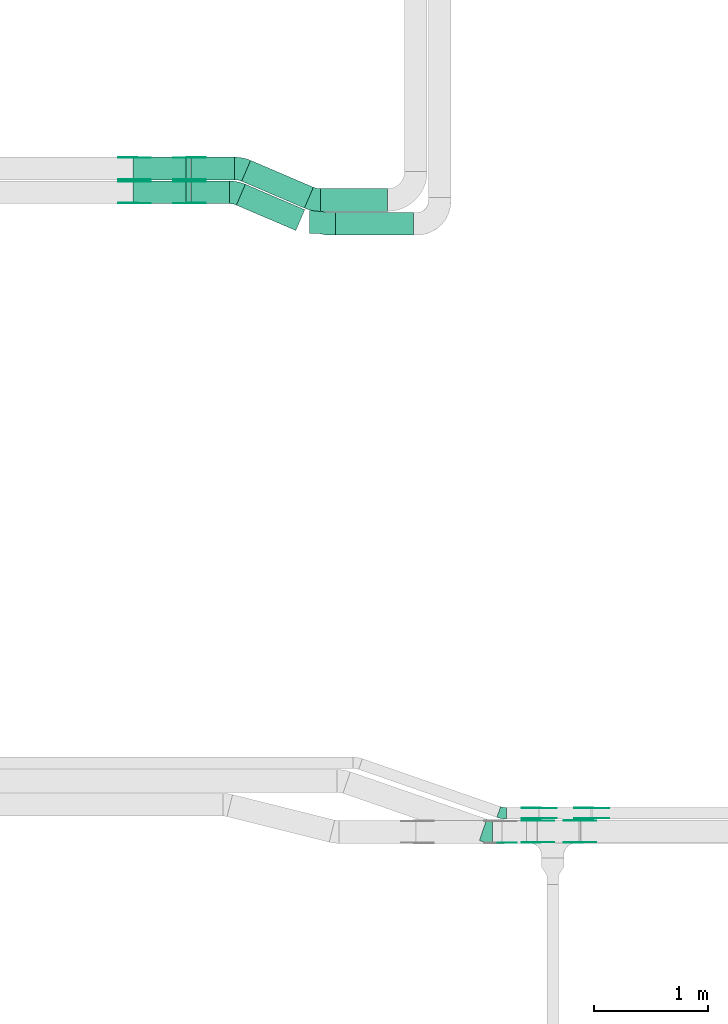
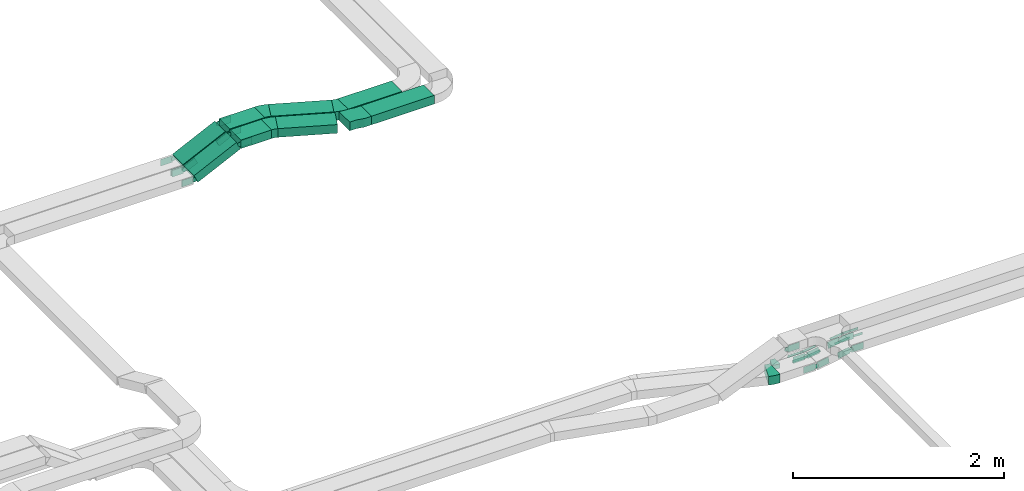
# One storey, part 14 of 23: 39 flow fittings, 8 flow segments.
"""IFC2X3 building model written with IfcOpenShell, lengths in millimetres."""

from ifc_helpers import new_model, entity, si_unit, converted_unit, derived_unit, direction, frame, frame_2d, origin, origin_2d_with_axis, place, context, subcontext, project, spatial, polyline, circle_curve, parameter, trimmed, segment, composite_curve, rectangle, outline, extrude, source, transform, mapped, material, type_object, type_shapes, element, save


model = new_model("IFC2X3")

# Units and contexts
model_context = context("Model", 3, precision=0.01, world=origin(), true_north=direction((6.12303176911189e-17, 1.0)))
body_context = subcontext(model_context, "Body", "Model", "MODEL_VIEW")
ifc_project = project(units=[si_unit("LENGTHUNIT", "METRE", prefix="MILLI"), si_unit("AREAUNIT", "SQUARE_METRE"), si_unit("VOLUMEUNIT", "CUBIC_METRE"), converted_unit("PLANEANGLEUNIT", "DEGREE", entity("IfcRatioMeasure", 0.0174532925199433), si_unit("PLANEANGLEUNIT", "RADIAN"), dimensions=[0, 0, 0, 0, 0, 0, 0]), si_unit("MASSUNIT", "GRAM", prefix="KILO"), derived_unit("MASSDENSITYUNIT", [(si_unit("MASSUNIT", "GRAM", prefix="KILO"), 1), (si_unit("LENGTHUNIT", "METRE"), -3)]), derived_unit("MOMENTOFINERTIAUNIT", [(si_unit("LENGTHUNIT", "METRE"), 4)]), si_unit("TIMEUNIT", "SECOND"), si_unit("FREQUENCYUNIT", "HERTZ"), si_unit("THERMODYNAMICTEMPERATUREUNIT", "DEGREE_CELSIUS"), derived_unit("THERMALTRANSMITTANCEUNIT", [(si_unit("MASSUNIT", "GRAM", prefix="KILO"), 1), (si_unit("THERMODYNAMICTEMPERATUREUNIT", "KELVIN"), -1), (si_unit("TIMEUNIT", "SECOND"), -3)]), derived_unit("VOLUMETRICFLOWRATEUNIT", [(si_unit("LENGTHUNIT", "METRE"), 3), (si_unit("TIMEUNIT", "SECOND"), -1)]), derived_unit("MASSFLOWRATEUNIT", [(si_unit("MASSUNIT", "GRAM", prefix="KILO"), 1), (si_unit("TIMEUNIT", "SECOND"), -1)]), derived_unit("ROTATIONALFREQUENCYUNIT", [(si_unit("TIMEUNIT", "SECOND"), -1)]), si_unit("ELECTRICCURRENTUNIT", "AMPERE"), si_unit("ELECTRICVOLTAGEUNIT", "VOLT"), si_unit("POWERUNIT", "WATT"), si_unit("FORCEUNIT", "NEWTON", prefix="KILO"), si_unit("ILLUMINANCEUNIT", "LUX"), si_unit("LUMINOUSFLUXUNIT", "LUMEN"), si_unit("LUMINOUSINTENSITYUNIT", "CANDELA"), derived_unit("USERDEFINED", [(si_unit("MASSUNIT", "GRAM", prefix="KILO"), -1), (si_unit("LENGTHUNIT", "METRE"), -2), (si_unit("TIMEUNIT", "SECOND"), 3), (si_unit("LUMINOUSFLUXUNIT", "LUMEN"), 1)]), derived_unit("LINEARVELOCITYUNIT", [(si_unit("LENGTHUNIT", "METRE"), 1), (si_unit("TIMEUNIT", "SECOND"), -1)]), si_unit("PRESSUREUNIT", "PASCAL"), derived_unit("USERDEFINED", [(si_unit("LENGTHUNIT", "METRE"), -2), (si_unit("MASSUNIT", "GRAM", prefix="KILO"), 1), (si_unit("TIMEUNIT", "SECOND"), -2)]), derived_unit("LINEARFORCEUNIT", [(si_unit("MASSUNIT", "GRAM", prefix="KILO"), 1), (si_unit("LENGTHUNIT", "METRE"), 1), (si_unit("TIMEUNIT", "SECOND"), -2), (si_unit("LENGTHUNIT", "METRE"), -1)]), derived_unit("PLANARFORCEUNIT", [(si_unit("MASSUNIT", "GRAM", prefix="KILO"), 1), (si_unit("LENGTHUNIT", "METRE"), 1), (si_unit("TIMEUNIT", "SECOND"), -2), (si_unit("LENGTHUNIT", "METRE"), -2)])], contexts=[model_context])

# Site, building, storey
site_placement = place(None, origin())
site = spatial("IfcSite", under=ifc_project, at=site_placement, CompositionType="ELEMENT")
building_placement = place(site_placement, origin())
building = spatial("IfcBuilding", under=site, at=building_placement, CompositionType="ELEMENT")
storey_placement = place(building_placement, frame((0.0, 0.0, 24000.0)))
storey = spatial("IfcBuildingStorey", under=building, at=storey_placement, CompositionType="ELEMENT", Elevation=24000.0)

# Flow segments
cable_carrier_segment_type = type_object("IfcCableCarrierSegmentType", PredefinedType="CABLETRAYSEGMENT")
flow_segment_1_placement = place(storey_placement, frame((39514.1, 14090.31, 2883.62)))
element("IfcFlowSegment", 1, at=flow_segment_1_placement, inside=storey, type_object=cable_carrier_segment_type, context=body_context, shape_type="SweptSolid", body=[
    extrude(rectangle(XDim=686.50102542503, YDim=199.999999999998, at=origin_2d_with_axis()), frame((343.25, 100.0, 0.0), z_axis=(0.0, 0.0, 1.0), x_axis=(-1.0, 0.0, 0.0)), (0.0, 0.0, 1.0), 100.000000000003),
])
flow_segment_2_placement = place(storey_placement, frame((39379.23, 14300.31, 2883.62)))
element("IfcFlowSegment", 2, at=flow_segment_2_placement, inside=storey, type_object=cable_carrier_segment_type, context=body_context, shape_type="SweptSolid", body=[
    extrude(rectangle(XDim=590.372485318248, YDim=199.999999999998, at=origin_2d_with_axis()), frame((295.19, 100.0, 0.0), z_axis=(0.0, 0.0, 1.0), x_axis=(-1.0, 0.0, 0.0)), (0.0, 0.0, 1.0), 100.000000000003),
])
flow_segment_3_placement = place(storey_placement, frame((38242.05, 14367.82, 2883.62)))
element("IfcFlowSegment", 3, at=flow_segment_3_placement, inside=storey, type_object=cable_carrier_segment_type, context=body_context, shape_type="SweptSolid", body=[
    extrude(rectangle(XDim=337.638555069506, YDim=199.999999999998, at=origin_2d_with_axis()), frame((168.82, 100.0, 0.0), z_axis=(0.0, 0.0, 1.0), x_axis=(-1.0, 0.0, 0.0)), (0.0, 0.0, 1.0), 100.000000000003),
])
flow_segment_4_placement = place(storey_placement, frame((38242.05, 14577.82, 2883.62)))
element("IfcFlowSegment", 4, at=flow_segment_4_placement, inside=storey, type_object=cable_carrier_segment_type, context=body_context, shape_type="SweptSolid", body=[
    extrude(rectangle(XDim=384.036141225792, YDim=199.999999999998, at=origin_2d_with_axis()), frame((192.02, 100.0, 0.0)), (0.0, 0.0, 1.0), 100.000000000003),
])
flow_segment_5_placement = place(storey_placement, frame((37730.99, 14367.82, 2660.62)))
element("IfcFlowSegment", 5, at=flow_segment_5_placement, inside=storey, type_object=cable_carrier_segment_type, context=body_context, shape_type="SweptSolid", body=[
    extrude(rectangle(XDim=99.9999999999961, YDim=200.000000000002, at=origin_2d_with_axis()), frame((21.58, 100.0, 45.1), z_axis=(0.90203010106071, 0.0, 0.431673136505395), x_axis=(-0.431673136505395, 0.0, 0.90203010106071)), (0.0, 0.0, 1.0), 514.687950468755),
])
flow_segment_6_placement = place(storey_placement, frame((37730.99, 14577.82, 2660.62)))
element("IfcFlowSegment", 6, at=flow_segment_6_placement, inside=storey, type_object=cable_carrier_segment_type, context=body_context, shape_type="SweptSolid", body=[
    extrude(rectangle(XDim=99.9999999999967, YDim=199.999999999998, at=origin_2d_with_axis()), frame((21.58, 100.0, 45.1), z_axis=(0.902030101062784, 0.0, 0.431673136501061), x_axis=(-0.431673136501061, 0.0, 0.902030101062784)), (0.0, 0.0, 1.0), 514.68795046868),
])
flow_segment_7_placement = place(storey_placement, frame((38640.61, 14131.35, 2883.62)))
element("IfcFlowSegment", 7, at=flow_segment_7_placement, inside=storey, type_object=cable_carrier_segment_type, context=body_context, shape_type="SweptSolid", body=[
    extrude(rectangle(XDim=569.477519390941, YDim=199.999999999997, at=origin_2d_with_axis()), frame((301.12, 203.93, 0.0), z_axis=(0.0, 0.0, 1.0), x_axis=(-0.919400368467263, 0.393322974745006, 0.0)), (0.0, 0.0, 1.0), 99.9999999999989),
])
flow_segment_8_placement = place(storey_placement, frame((38687.0, 14328.92, 2883.62)))
element("IfcFlowSegment", 8, at=flow_segment_8_placement, inside=storey, type_object=cable_carrier_segment_type, context=body_context, shape_type="SweptSolid", body=[
    extrude(rectangle(XDim=601.090303341187, YDim=199.999999999999, at=origin_2d_with_axis()), frame((315.65, 210.15, 0.0), z_axis=(0.0, 0.0, 1.0), x_axis=(-0.919400368467261, 0.393322974745012, 0.0)), (0.0, 0.0, 1.0), 100.000000000003),
])

# Flow fittings
ifc_material_1 = material()
cable_carrier_fitting_type_1 = type_object("IfcCableCarrierFittingType", PredefinedType="NOTDEFINED", material=ifc_material_1)
shared_shape_1 = source(origin(), body_context, "Body", "SweptSolid", [
    extrude(outline(polyline([(-115.0, 91.77), (-115.0, -108.23), (-38.33, -108.23), (38.33, -91.77), (115.0, -91.77), (115.0, 108.23), (38.33, 108.23), (-38.33, 91.77), (-115.0, 91.77)])), frame((115.0, -8.23, -50.0), z_axis=(0.0, 0.0, -1.0), x_axis=(1.0, 0.0, 0.0)), (0.0, 0.0, -1.0), 100.0),
])
type_shapes(cable_carrier_fitting_type_1, [shared_shape_1])
flow_fitting_1_placement = place(storey_placement, frame((39514.1, 14190.31, 2933.62), z_axis=(0.0, 0.0, 1.0), x_axis=(-1.0, 0.0, 0.0)))
element("IfcFlowFitting", 9, at=flow_fitting_1_placement, inside=storey, type_object=cable_carrier_fitting_type_1, material=ifc_material_1, Name="470_DKC_S5_adapter", context=body_context, shape_type="MappedRepresentation", body=[
    mapped(shared_shape_1, transform((0.0, 0.0, 0.0), scale=1.0)),
])
ifc_material_2 = material(Name="G")
cable_carrier_fitting_type_2 = type_object("IfcCableCarrierFittingType", PredefinedType="NOTDEFINED", material=ifc_material_2)
shared_shape_2 = source(origin(), body_context, "Body", "SweptSolid", [
    extrude(outline(composite_curve([segment(trimmed(circle_curve(frame_2d((-44.59, 0.0), x_axis=(1.0, 0.0)), 12.5), [parameter(90.0000000000007)], [parameter(270.0)], True, "PARAMETER"), True, "CONTINUOUS"), segment(polyline([(-44.59, -12.5), (-33.09, -12.5)]), True, "CONTINUOUS"), segment(polyline([(-33.09, -12.5), (-31.23, -14.5)]), True, "CONTINUOUS"), segment(polyline([(-31.23, -14.5), (108.91, -14.5)]), True, "CONTINUOUS"), segment(polyline([(108.91, -14.5), (108.91, 14.5)]), True, "CONTINUOUS"), segment(polyline([(108.91, 14.5), (-31.23, 14.5)]), True, "CONTINUOUS"), segment(polyline([(-31.23, 14.5), (-33.09, 12.5)]), True, "CONTINUOUS"), segment(polyline([(-33.09, 12.5), (-44.59, 12.5)]), True, "CONTINUOUS")], self_intersect=False)), frame((44.59, 0.0, 0.0), z_axis=(0.0, 0.0, -1.0), x_axis=(1.0, 0.0, 0.0)), (0.0, 0.0, -1.0), 2.0),
])
type_shapes(cable_carrier_fitting_type_2, [shared_shape_2])
flow_fitting_2_placement = place(storey_placement, frame((41768.97, 8954.53, 2745.0), z_axis=(0.0, -1.0, 0.0), x_axis=(-0.991697353687333, 0.0, -0.128593773914372)))
element("IfcFlowFitting", 10, at=flow_fitting_2_placement, inside=storey, type_object=cable_carrier_fitting_type_2, material=ifc_material_2, context=body_context, shape_type="MappedRepresentation", body=[
    mapped(shared_shape_2, transform((0.0, 0.0, 0.0), scale=1.0)),
])
cable_carrier_fitting_type_3 = type_object("IfcCableCarrierFittingType", PredefinedType="NOTDEFINED", material=ifc_material_2)
type_shapes(cable_carrier_fitting_type_3, [shared_shape_2])
flow_fitting_3_placement = place(storey_placement, frame((41768.97, 9043.45, 2745.0), z_axis=(0.0, 1.0, 0.0), x_axis=(1.0, 0.0, 0.0)))
element("IfcFlowFitting", 11, at=flow_fitting_3_placement, inside=storey, type_object=cable_carrier_fitting_type_3, material=ifc_material_2, context=body_context, shape_type="MappedRepresentation", body=[
    mapped(shared_shape_2, transform((0.0, 0.0, 0.0), scale=1.0)),
])
flow_fitting_4_placement = place(storey_placement, frame((41306.26, 9045.45, 2685.0), z_axis=(0.0, 1.0, 0.0), x_axis=(-1.0, 0.0, 0.0)))
element("IfcFlowFitting", 12, at=flow_fitting_4_placement, inside=storey, type_object=cable_carrier_fitting_type_2, material=ifc_material_2, context=body_context, shape_type="MappedRepresentation", body=[
    mapped(shared_shape_2, transform((0.0, 0.0, 0.0), scale=1.0)),
])
flow_fitting_5_placement = place(storey_placement, frame((41306.26, 8956.53, 2685.0), z_axis=(0.0, -1.0, 0.0), x_axis=(0.991697353687344, 0.0, 0.128593773914286)))
element("IfcFlowFitting", 13, at=flow_fitting_5_placement, inside=storey, type_object=cable_carrier_fitting_type_3, material=ifc_material_2, context=body_context, shape_type="MappedRepresentation", body=[
    mapped(shared_shape_2, transform((0.0, 0.0, 0.0), scale=1.0)),
])
cable_carrier_fitting_type_4 = type_object("IfcCableCarrierFittingType", PredefinedType="NOTDEFINED", material=ifc_material_2)
shared_shape_3 = source(origin(), body_context, "Body", "SweptSolid", [
    extrude(outline(composite_curve([segment(trimmed(circle_curve(frame_2d((-44.59, 0.0), x_axis=(1.0, 0.0)), 12.5), [parameter(90.0000000000007)], [parameter(270.0)], True, "PARAMETER"), True, "CONTINUOUS"), segment(polyline([(-44.59, -12.5), (-33.09, -12.5)]), True, "CONTINUOUS"), segment(polyline([(-33.09, -12.5), (-31.23, -14.5)]), True, "CONTINUOUS"), segment(polyline([(-31.23, -14.5), (108.91, -14.5)]), True, "CONTINUOUS"), segment(polyline([(108.91, -14.5), (108.91, 14.5)]), True, "CONTINUOUS"), segment(polyline([(108.91, 14.5), (-31.23, 14.5)]), True, "CONTINUOUS"), segment(polyline([(-31.23, 14.5), (-33.09, 12.5)]), True, "CONTINUOUS"), segment(polyline([(-33.09, 12.5), (-44.59, 12.5)]), True, "CONTINUOUS")], self_intersect=False)), frame((44.59, 0.0, 0.0)), (0.0, 0.0, 1.0), 2.0),
])
type_shapes(cable_carrier_fitting_type_4, [shared_shape_3])
flow_fitting_6_placement = place(storey_placement, frame((41768.97, 9045.45, 2745.0), z_axis=(0.0, 1.0, 0.0), x_axis=(-0.991697353687333, 0.0, -0.128593773914372)))
element("IfcFlowFitting", 14, at=flow_fitting_6_placement, inside=storey, type_object=cable_carrier_fitting_type_4, material=ifc_material_2, context=body_context, shape_type="MappedRepresentation", body=[
    mapped(shared_shape_3, transform((0.0, 0.0, 0.0), scale=1.0)),
])
cable_carrier_fitting_type_5 = type_object("IfcCableCarrierFittingType", PredefinedType="NOTDEFINED", material=ifc_material_2)
type_shapes(cable_carrier_fitting_type_5, [shared_shape_3])
flow_fitting_7_placement = place(storey_placement, frame((41768.97, 8956.53, 2745.0), z_axis=(0.0, -1.0, 0.0), x_axis=(1.0, 0.0, 0.0)))
element("IfcFlowFitting", 15, at=flow_fitting_7_placement, inside=storey, type_object=cable_carrier_fitting_type_5, material=ifc_material_2, context=body_context, shape_type="MappedRepresentation", body=[
    mapped(shared_shape_3, transform((0.0, 0.0, 0.0), scale=1.0)),
])
flow_fitting_8_placement = place(storey_placement, frame((41306.26, 8954.53, 2685.0), z_axis=(0.0, -1.0, 0.0), x_axis=(-1.0, 0.0, 0.0)))
element("IfcFlowFitting", 16, at=flow_fitting_8_placement, inside=storey, type_object=cable_carrier_fitting_type_4, material=ifc_material_2, context=body_context, shape_type="MappedRepresentation", body=[
    mapped(shared_shape_3, transform((0.0, 0.0, 0.0), scale=1.0)),
])
flow_fitting_9_placement = place(storey_placement, frame((41306.26, 9043.45, 2685.0), z_axis=(0.0, 1.0, 0.0), x_axis=(0.991697353687344, 0.0, 0.128593773914286)))
element("IfcFlowFitting", 17, at=flow_fitting_9_placement, inside=storey, type_object=cable_carrier_fitting_type_5, material=ifc_material_2, context=body_context, shape_type="MappedRepresentation", body=[
    mapped(shared_shape_3, transform((0.0, 0.0, 0.0), scale=1.0)),
])
cable_carrier_fitting_type_6 = type_object("IfcCableCarrierFittingType", PredefinedType="NOTDEFINED", material=ifc_material_2)
shared_shape_4 = source(origin(), body_context, "Body", "SweptSolid", [
    extrude(outline(composite_curve([segment(trimmed(circle_curve(frame_2d((-41.47, 0.0), x_axis=(1.0, 0.0)), 25.0), [parameter(90.0000000000007)], [parameter(270.0)], True, "PARAMETER"), True, "CONTINUOUS"), segment(polyline([(-41.47, -25.0), (-29.97, -25.0)]), True, "CONTINUOUS"), segment(polyline([(-29.97, -25.0), (-28.1, -38.5)]), True, "CONTINUOUS"), segment(polyline([(-28.1, -38.5), (99.53, -38.5)]), True, "CONTINUOUS"), segment(polyline([(99.53, -38.5), (99.53, 38.5)]), True, "CONTINUOUS"), segment(polyline([(99.53, 38.5), (-28.1, 38.5)]), True, "CONTINUOUS"), segment(polyline([(-28.1, 38.5), (-29.97, 25.0)]), True, "CONTINUOUS"), segment(polyline([(-29.97, 25.0), (-41.47, 25.0)]), True, "CONTINUOUS")], self_intersect=False)), frame((41.47, 0.0, 0.0), z_axis=(0.0, 0.0, -1.0), x_axis=(1.0, 0.0, 0.0)), (0.0, 0.0, -1.0), 2.0),
])
type_shapes(cable_carrier_fitting_type_6, [shared_shape_4])
flow_fitting_10_placement = place(storey_placement, frame((38228.79, 14372.36, 2933.62), z_axis=(0.0, -1.0, 0.0), x_axis=(-0.902030101060717, 0.0, -0.43167313650538)))
element("IfcFlowFitting", 18, at=flow_fitting_10_placement, inside=storey, type_object=cable_carrier_fitting_type_6, material=ifc_material_2, context=body_context, shape_type="MappedRepresentation", body=[
    mapped(shared_shape_4, transform((0.0, 0.0, 0.0), scale=1.0)),
])
cable_carrier_fitting_type_7 = type_object("IfcCableCarrierFittingType", PredefinedType="NOTDEFINED", material=ifc_material_2)
type_shapes(cable_carrier_fitting_type_7, [shared_shape_4])
flow_fitting_11_placement = place(storey_placement, frame((38228.79, 14561.28, 2933.62), z_axis=(0.0, 1.0, 0.0), x_axis=(1.0, 0.0, 0.0)))
element("IfcFlowFitting", 19, at=flow_fitting_11_placement, inside=storey, type_object=cable_carrier_fitting_type_7, material=ifc_material_2, context=body_context, shape_type="MappedRepresentation", body=[
    mapped(shared_shape_4, transform((0.0, 0.0, 0.0), scale=1.0)),
])
flow_fitting_12_placement = place(storey_placement, frame((37740.62, 14372.36, 2700.0), z_axis=(0.0, -1.0, 0.0), x_axis=(0.902030101060717, 0.0, 0.43167313650538)))
element("IfcFlowFitting", 20, at=flow_fitting_12_placement, inside=storey, type_object=cable_carrier_fitting_type_6, material=ifc_material_2, context=body_context, shape_type="MappedRepresentation", body=[
    mapped(shared_shape_4, transform((0.0, 0.0, 0.0), scale=1.0)),
])
flow_fitting_13_placement = place(storey_placement, frame((37740.62, 14561.28, 2700.0), z_axis=(0.0, 1.0, 0.0), x_axis=(-1.0, 0.0, 0.0)))
element("IfcFlowFitting", 21, at=flow_fitting_13_placement, inside=storey, type_object=cable_carrier_fitting_type_7, material=ifc_material_2, context=body_context, shape_type="MappedRepresentation", body=[
    mapped(shared_shape_4, transform((0.0, 0.0, 0.0), scale=1.0)),
])
flow_fitting_14_placement = place(storey_placement, frame((38228.79, 14773.28, 2933.62), z_axis=(0.0, 1.0, 0.0), x_axis=(1.0, 0.0, 0.0)))
element("IfcFlowFitting", 22, at=flow_fitting_14_placement, inside=storey, type_object=cable_carrier_fitting_type_6, material=ifc_material_2, context=body_context, shape_type="MappedRepresentation", body=[
    mapped(shared_shape_4, transform((0.0, 0.0, 0.0), scale=1.0)),
])
flow_fitting_15_placement = place(storey_placement, frame((38228.79, 14584.36, 2933.62), z_axis=(0.0, -1.0, 0.0), x_axis=(-0.90203010106066, 0.0, -0.431673136505499)))
element("IfcFlowFitting", 23, at=flow_fitting_15_placement, inside=storey, type_object=cable_carrier_fitting_type_7, material=ifc_material_2, context=body_context, shape_type="MappedRepresentation", body=[
    mapped(shared_shape_4, transform((0.0, 0.0, 0.0), scale=1.0)),
])
flow_fitting_16_placement = place(storey_placement, frame((41668.97, 8744.53, 2770.0), z_axis=(0.0, -1.0, 0.0), x_axis=(-0.98749875444872, 0.0, -0.1576268059761)))
element("IfcFlowFitting", 24, at=flow_fitting_16_placement, inside=storey, type_object=cable_carrier_fitting_type_6, material=ifc_material_2, context=body_context, shape_type="MappedRepresentation", body=[
    mapped(shared_shape_4, transform((0.0, 0.0, 0.0), scale=1.0)),
])
flow_fitting_17_placement = place(storey_placement, frame((41668.97, 8933.45, 2770.0), z_axis=(0.0, 1.0, 0.0), x_axis=(1.0, 0.0, 0.0)))
element("IfcFlowFitting", 25, at=flow_fitting_17_placement, inside=storey, type_object=cable_carrier_fitting_type_7, material=ifc_material_2, context=body_context, shape_type="MappedRepresentation", body=[
    mapped(shared_shape_4, transform((0.0, 0.0, 0.0), scale=1.0)),
])
flow_fitting_18_placement = place(storey_placement, frame((41293.08, 8935.45, 2710.0), z_axis=(0.0, 1.0, 0.0), x_axis=(-1.0, 0.0, 0.0)))
element("IfcFlowFitting", 26, at=flow_fitting_18_placement, inside=storey, type_object=cable_carrier_fitting_type_6, material=ifc_material_2, context=body_context, shape_type="MappedRepresentation", body=[
    mapped(shared_shape_4, transform((0.0, 0.0, 0.0), scale=1.0)),
])
flow_fitting_19_placement = place(storey_placement, frame((41293.08, 8746.53, 2710.0), z_axis=(0.0, -1.0, 0.0), x_axis=(0.987498754448717, 0.0, 0.157626805976115)))
element("IfcFlowFitting", 27, at=flow_fitting_19_placement, inside=storey, type_object=cable_carrier_fitting_type_7, material=ifc_material_2, context=body_context, shape_type="MappedRepresentation", body=[
    mapped(shared_shape_4, transform((0.0, 0.0, 0.0), scale=1.0)),
])
flow_fitting_20_placement = place(storey_placement, frame((37740.62, 14773.28, 2700.0), z_axis=(0.0, 1.0, 0.0), x_axis=(-1.0, 0.0, 0.0)))
element("IfcFlowFitting", 28, at=flow_fitting_20_placement, inside=storey, type_object=cable_carrier_fitting_type_6, material=ifc_material_2, context=body_context, shape_type="MappedRepresentation", body=[
    mapped(shared_shape_4, transform((0.0, 0.0, 0.0), scale=1.0)),
])
flow_fitting_21_placement = place(storey_placement, frame((37740.62, 14584.36, 2700.0), z_axis=(0.0, -1.0, 0.0), x_axis=(0.902030101062787, 0.0, 0.431673136501055)))
element("IfcFlowFitting", 29, at=flow_fitting_21_placement, inside=storey, type_object=cable_carrier_fitting_type_7, material=ifc_material_2, context=body_context, shape_type="MappedRepresentation", body=[
    mapped(shared_shape_4, transform((0.0, 0.0, 0.0), scale=1.0)),
])
cable_carrier_fitting_type_8 = type_object("IfcCableCarrierFittingType", PredefinedType="NOTDEFINED", material=ifc_material_2)
shared_shape_5 = source(origin(), body_context, "Body", "SweptSolid", [
    extrude(outline(composite_curve([segment(trimmed(circle_curve(frame_2d((-41.47, 0.0), x_axis=(1.0, 0.0)), 25.0), [parameter(90.0000000000007)], [parameter(270.0)], True, "PARAMETER"), True, "CONTINUOUS"), segment(polyline([(-41.47, -25.0), (-29.97, -25.0)]), True, "CONTINUOUS"), segment(polyline([(-29.97, -25.0), (-28.1, -38.5)]), True, "CONTINUOUS"), segment(polyline([(-28.1, -38.5), (99.53, -38.5)]), True, "CONTINUOUS"), segment(polyline([(99.53, -38.5), (99.53, 38.5)]), True, "CONTINUOUS"), segment(polyline([(99.53, 38.5), (-28.1, 38.5)]), True, "CONTINUOUS"), segment(polyline([(-28.1, 38.5), (-29.97, 25.0)]), True, "CONTINUOUS"), segment(polyline([(-29.97, 25.0), (-41.47, 25.0)]), True, "CONTINUOUS")], self_intersect=False)), frame((41.47, 0.0, 0.0)), (0.0, 0.0, 1.0), 2.0),
])
type_shapes(cable_carrier_fitting_type_8, [shared_shape_5])
flow_fitting_22_placement = place(storey_placement, frame((38228.79, 14563.28, 2933.62), z_axis=(0.0, 1.0, 0.0), x_axis=(-0.902030101060717, 0.0, -0.43167313650538)))
element("IfcFlowFitting", 30, at=flow_fitting_22_placement, inside=storey, type_object=cable_carrier_fitting_type_8, material=ifc_material_2, context=body_context, shape_type="MappedRepresentation", body=[
    mapped(shared_shape_5, transform((0.0, 0.0, 0.0), scale=1.0)),
])
cable_carrier_fitting_type_9 = type_object("IfcCableCarrierFittingType", PredefinedType="NOTDEFINED", material=ifc_material_2)
type_shapes(cable_carrier_fitting_type_9, [shared_shape_5])
flow_fitting_23_placement = place(storey_placement, frame((38228.79, 14374.36, 2933.62), z_axis=(0.0, -1.0, 0.0), x_axis=(1.0, 0.0, 0.0)))
element("IfcFlowFitting", 31, at=flow_fitting_23_placement, inside=storey, type_object=cable_carrier_fitting_type_9, material=ifc_material_2, context=body_context, shape_type="MappedRepresentation", body=[
    mapped(shared_shape_5, transform((0.0, 0.0, 0.0), scale=1.0)),
])
flow_fitting_24_placement = place(storey_placement, frame((37740.62, 14563.28, 2700.0), z_axis=(0.0, 1.0, 0.0), x_axis=(0.902030101060717, 0.0, 0.43167313650538)))
element("IfcFlowFitting", 32, at=flow_fitting_24_placement, inside=storey, type_object=cable_carrier_fitting_type_8, material=ifc_material_2, context=body_context, shape_type="MappedRepresentation", body=[
    mapped(shared_shape_5, transform((0.0, 0.0, 0.0), scale=1.0)),
])
flow_fitting_25_placement = place(storey_placement, frame((37740.62, 14374.36, 2700.0), z_axis=(0.0, -1.0, 0.0), x_axis=(-1.0, 0.0, 0.0)))
element("IfcFlowFitting", 33, at=flow_fitting_25_placement, inside=storey, type_object=cable_carrier_fitting_type_9, material=ifc_material_2, context=body_context, shape_type="MappedRepresentation", body=[
    mapped(shared_shape_5, transform((0.0, 0.0, 0.0), scale=1.0)),
])
flow_fitting_26_placement = place(storey_placement, frame((38228.79, 14582.36, 2933.62), z_axis=(0.0, -1.0, 0.0), x_axis=(1.0, 0.0, 0.0)))
element("IfcFlowFitting", 34, at=flow_fitting_26_placement, inside=storey, type_object=cable_carrier_fitting_type_8, material=ifc_material_2, context=body_context, shape_type="MappedRepresentation", body=[
    mapped(shared_shape_5, transform((0.0, 0.0, 0.0), scale=1.0)),
])
for number, where, z_axis, x_axis in (
    (35, (38228.79, 14771.28, 2933.62), (0.0, 1.0, 0.0), (-0.90203010106066, 0.0, -0.431673136505499)),
    (36, (40968.97, 8741.53, 3020.0), (0.0, -1.0, 0.0), (1.0, 0.0, 0.0)),
):
    element("IfcFlowFitting", number, at=place(storey_placement, frame(where, z_axis=z_axis, x_axis=x_axis)), inside=storey, type_object=cable_carrier_fitting_type_9, material=ifc_material_2, context=body_context, shape_type="MappedRepresentation", body=[
        mapped(shared_shape_5, transform((0.0, 0.0, 0.0), scale=1.0)),
    ])
flow_fitting_27_placement = place(storey_placement, frame((41668.97, 8935.45, 2770.0), z_axis=(0.0, 1.0, 0.0), x_axis=(-0.98749875444872, 0.0, -0.1576268059761)))
element("IfcFlowFitting", 37, at=flow_fitting_27_placement, inside=storey, type_object=cable_carrier_fitting_type_8, material=ifc_material_2, context=body_context, shape_type="MappedRepresentation", body=[
    mapped(shared_shape_5, transform((0.0, 0.0, 0.0), scale=1.0)),
])
flow_fitting_28_placement = place(storey_placement, frame((41668.97, 8746.53, 2770.0), z_axis=(0.0, -1.0, 0.0), x_axis=(1.0, 0.0, 0.0)))
element("IfcFlowFitting", 38, at=flow_fitting_28_placement, inside=storey, type_object=cable_carrier_fitting_type_9, material=ifc_material_2, context=body_context, shape_type="MappedRepresentation", body=[
    mapped(shared_shape_5, transform((0.0, 0.0, 0.0), scale=1.0)),
])
flow_fitting_29_placement = place(storey_placement, frame((41293.08, 8744.53, 2710.0), z_axis=(0.0, -1.0, 0.0), x_axis=(-1.0, 0.0, 0.0)))
element("IfcFlowFitting", 39, at=flow_fitting_29_placement, inside=storey, type_object=cable_carrier_fitting_type_8, material=ifc_material_2, context=body_context, shape_type="MappedRepresentation", body=[
    mapped(shared_shape_5, transform((0.0, 0.0, 0.0), scale=1.0)),
])
flow_fitting_30_placement = place(storey_placement, frame((41293.08, 8933.45, 2710.0), z_axis=(0.0, 1.0, 0.0), x_axis=(0.987498754448717, 0.0, 0.157626805976115)))
element("IfcFlowFitting", 40, at=flow_fitting_30_placement, inside=storey, type_object=cable_carrier_fitting_type_9, material=ifc_material_2, context=body_context, shape_type="MappedRepresentation", body=[
    mapped(shared_shape_5, transform((0.0, 0.0, 0.0), scale=1.0)),
])
flow_fitting_31_placement = place(storey_placement, frame((37740.62, 14582.36, 2700.0), z_axis=(0.0, -1.0, 0.0), x_axis=(-1.0, 0.0, 0.0)))
element("IfcFlowFitting", 41, at=flow_fitting_31_placement, inside=storey, type_object=cable_carrier_fitting_type_8, material=ifc_material_2, context=body_context, shape_type="MappedRepresentation", body=[
    mapped(shared_shape_5, transform((0.0, 0.0, 0.0), scale=1.0)),
])
flow_fitting_32_placement = place(storey_placement, frame((37740.62, 14771.28, 2700.0), z_axis=(0.0, 1.0, 0.0), x_axis=(0.902030101062787, 0.0, 0.431673136501055)))
element("IfcFlowFitting", 42, at=flow_fitting_32_placement, inside=storey, type_object=cable_carrier_fitting_type_9, material=ifc_material_2, context=body_context, shape_type="MappedRepresentation", body=[
    mapped(shared_shape_5, transform((0.0, 0.0, 0.0), scale=1.0)),
])
cable_carrier_fitting_type_10 = type_object("IfcCableCarrierFittingType", Name="470_DKC_S5_Variable Angle Elbow 0-45:-", PredefinedType="NOTDEFINED", material=ifc_material_1)
shared_shape_6 = source(origin(), body_context, "Body", "SweptSolid", [
    extrude(outline(composite_curve([segment(polyline([(-50.15, -110.17), (-49.15, -110.17)]), True, "CONTINUOUS"), segment(trimmed(circle_curve(frame_2d((-49.15, 239.83), x_axis=(0.0, -1.0)), 350.0), [parameter(0.0)], [parameter(23.1614232641994)], True, "PARAMETER"), True, "CONTINUOUS"), segment(polyline([(88.52, -81.96), (89.44, -81.57)]), True, "CONTINUOUS"), segment(polyline([(89.44, -81.57), (10.77, 102.31)]), True, "CONTINUOUS"), segment(polyline([(10.77, 102.31), (9.85, 101.92)]), True, "CONTINUOUS"), segment(trimmed(circle_curve(frame_2d((-49.15, 239.83), x_axis=(0.0, -1.0)), 150.0), [parameter(0.0)], [parameter(23.1614232641994)], True, "PARAMETER"), False, "CONTINUOUS"), segment(polyline([(-49.15, 89.83), (-50.15, 89.83)]), True, "CONTINUOUS"), segment(polyline([(-50.15, 89.83), (-50.15, -110.17)]), True, "CONTINUOUS")], self_intersect=False)), frame((-2.08, 10.17, -50.0)), (0.0, 0.0, 1.0), 100.0),
])
type_shapes(cable_carrier_fitting_type_10, [shared_shape_6])
for number, where, z_axis, x_axis, name in (
    (43, (38631.92, 14467.82, 2933.62), (0.0, 0.0, 1.0), (-0.91940036846727, 0.393322974744991, 0.0), "470_DKC_S5_Variable Angle Elbow 0-45:-"),
    (44, (39327.0, 14400.31, 2933.62), (0.0, 0.0, 1.0), (0.91940036846726, -0.393322974745013, 0.0), "470_DKC_S5_Variable Angle Elbow 0-45:-"),
    (45, (38678.32, 14677.82, 2933.62), (0.0, 0.0, 1.0), (-0.919400368467258, 0.393322974745018, 0.0), "470_DKC_S5_Variable Angle Elbow 0-45:-"),
):
    element("IfcFlowFitting", number, at=place(storey_placement, frame(where, z_axis=z_axis, x_axis=x_axis)), inside=storey, type_object=cable_carrier_fitting_type_10, material=ifc_material_1, Name=name, ObjectType="470_DKC_S5_Variable Angle Elbow 0-45:-", context=body_context, shape_type="MappedRepresentation", body=[
        mapped(shared_shape_6, transform((0.0, 0.0, 0.0), scale=1.0)),
    ])
cable_carrier_fitting_type_11 = type_object("IfcCableCarrierFittingType", Name="470_DKC_S5_Variable Angle Elbow 0-45:-", PredefinedType="NOTDEFINED", material=ifc_material_1)
shared_shape_7 = source(origin(), body_context, "Body", "SweptSolid", [
    extrude(outline(composite_curve([segment(polyline([(-41.96, -106.99), (-40.96, -106.99)]), True, "CONTINUOUS"), segment(trimmed(circle_curve(frame_2d((-40.96, 243.01), x_axis=(0.0, -1.0)), 350.0), [parameter(0.0)], [parameter(19.136971841609)], True, "PARAMETER"), True, "CONTINUOUS"), segment(polyline([(73.78, -87.65), (74.72, -87.32)]), True, "CONTINUOUS"), segment(polyline([(74.72, -87.32), (9.15, 101.63)]), True, "CONTINUOUS"), segment(polyline([(9.15, 101.63), (8.21, 101.3)]), True, "CONTINUOUS"), segment(trimmed(circle_curve(frame_2d((-40.96, 243.01), x_axis=(0.0, -1.0)), 150.0), [parameter(0.0)], [parameter(19.136971841609)], True, "PARAMETER"), False, "CONTINUOUS"), segment(polyline([(-40.96, 93.01), (-41.96, 93.01)]), True, "CONTINUOUS"), segment(polyline([(-41.96, 93.01), (-41.96, -106.99)]), True, "CONTINUOUS")], self_intersect=False)), frame((-1.18, 6.99, -50.0)), (0.0, 0.0, 1.0), 100.0),
])
type_shapes(cable_carrier_fitting_type_11, [shared_shape_7])
flow_fitting_33_placement = place(storey_placement, frame((40853.08, 8839.99, 2710.0), z_axis=(0.0, 0.0, 1.0), x_axis=(0.944737568154264, -0.327827587792681, 0.0)))
element("IfcFlowFitting", 46, at=flow_fitting_33_placement, inside=storey, type_object=cable_carrier_fitting_type_11, material=ifc_material_1, Name="470_DKC_S5_Variable Angle Elbow 0-45:-", ObjectType="470_DKC_S5_Variable Angle Elbow 0-45:-", context=body_context, shape_type="MappedRepresentation", body=[
    mapped(shared_shape_7, transform((0.0, 0.0, 0.0), scale=1.0)),
])
cable_carrier_fitting_type_12 = type_object("IfcCableCarrierFittingType", Name="470_DKC_S5_Variable Angle Elbow 0-45:-", PredefinedType="NOTDEFINED", material=ifc_material_1)
shared_shape_8 = source(origin(), body_context, "Body", "SweptSolid", [
    extrude(outline(composite_curve([segment(polyline([(-33.77, -55.61), (-32.77, -55.61)]), True, "CONTINUOUS"), segment(trimmed(circle_curve(frame_2d((-32.77, 194.39), x_axis=(0.0, -1.0)), 250.0), [parameter(0.0)], [parameter(19.1369718416102)], True, "PARAMETER"), True, "CONTINUOUS"), segment(polyline([(49.19, -41.79), (50.13, -41.46)]), True, "CONTINUOUS"), segment(polyline([(50.13, -41.46), (17.35, 53.01)]), True, "CONTINUOUS"), segment(polyline([(17.35, 53.01), (16.41, 52.68)]), True, "CONTINUOUS"), segment(trimmed(circle_curve(frame_2d((-32.77, 194.39), x_axis=(0.0, -1.0)), 150.0), [parameter(0.0)], [parameter(19.1369718416102)], True, "PARAMETER"), False, "CONTINUOUS"), segment(polyline([(-32.77, 44.39), (-33.77, 44.39)]), True, "CONTINUOUS"), segment(polyline([(-33.77, 44.39), (-33.77, -55.61)]), True, "CONTINUOUS")], self_intersect=False)), frame((-0.95, 5.61, -25.0)), (0.0, 0.0, 1.0), 50.0000000000001),
])
type_shapes(cable_carrier_fitting_type_12, [shared_shape_8])
flow_fitting_34_placement = place(storey_placement, frame((40983.08, 8999.99, 2685.0), z_axis=(0.0, 0.0, 1.0), x_axis=(0.944737568154258, -0.327827587792697, 0.0)))
element("IfcFlowFitting", 47, at=flow_fitting_34_placement, inside=storey, type_object=cable_carrier_fitting_type_12, material=ifc_material_1, Name="470_DKC_S5_Variable Angle Elbow 0-45:-", ObjectType="470_DKC_S5_Variable Angle Elbow 0-45:-", context=body_context, shape_type="MappedRepresentation", body=[
    mapped(shared_shape_8, transform((0.0, 0.0, 0.0), scale=1.0)),
])

save(model, "model.ifc")
